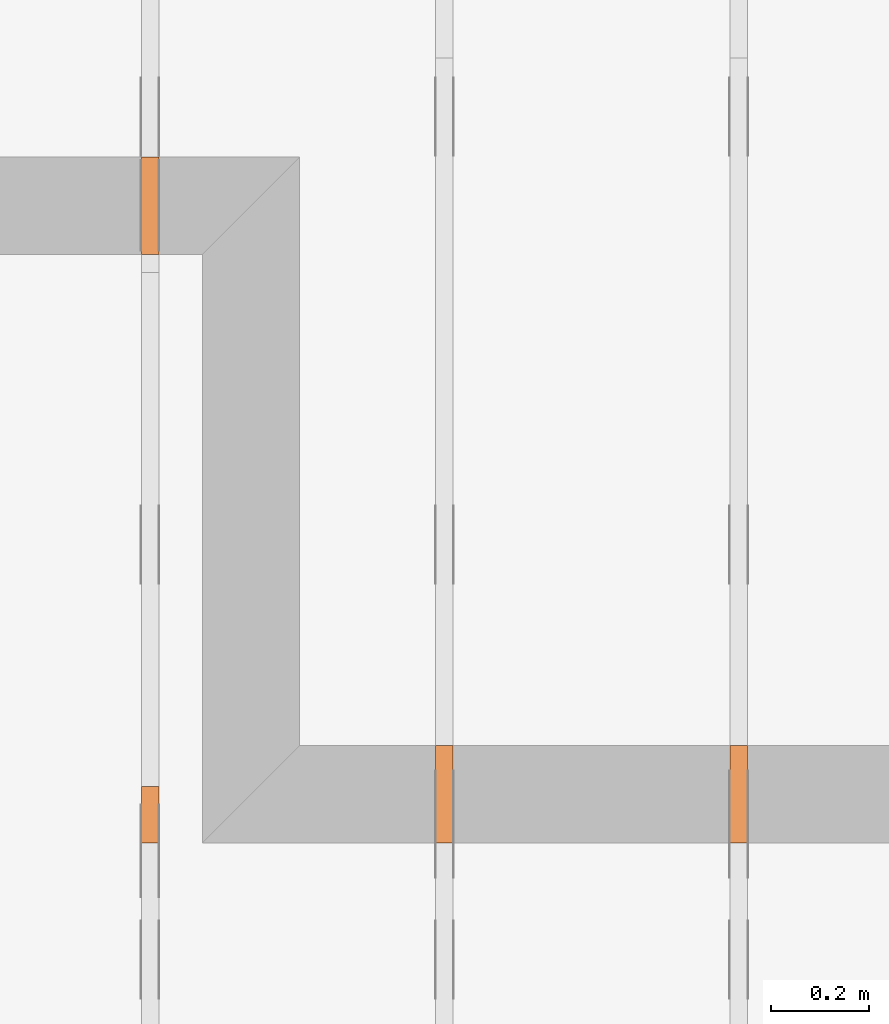
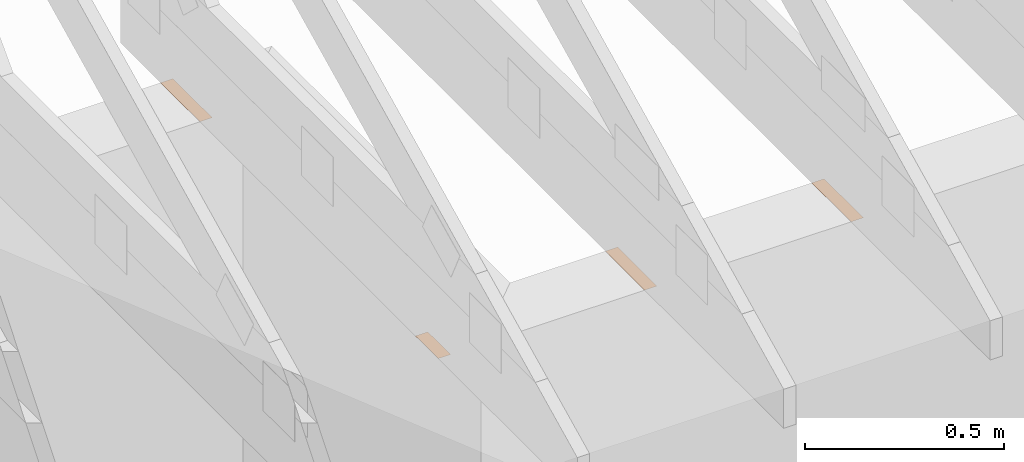
# One storey, part 142 of 159: 4 proxies, 3 elements without a shape of their own.
"""IFC2X3 building model written with IfcOpenShell, lengths in millimetres."""

import ifcopenshell
import ifcopenshell.guid

model = None  # the IFC model being written
_history = None  # IfcOwnerHistory: only IFC2X3 demands one
_inside = {}  # id of a spatial element -> (the spatial element, [elements in it])
_under = {}  # id of a project, library or spatial element -> (it, [spatial elements below it])
_declared = {}  # id of a project -> (the project, [libraries it declares])
_typed = {}  # id of a type object -> (the type object, [elements of that type])
_made_of = {}  # id of a material, layer set ... -> (it, [elements and type objects made of it])


def new_model(schema):
    """Start an empty IFC model of exactly this schema.

    Asked for "IFC4X3", IfcOpenShell would pick the latest addendum, in which some entities
    have other attributes; the version numbers below select the first issue.
    IFC2X3 requires an IfcOwnerHistory on every rooted entity: one is made here for all.
    """
    global model, _history
    if schema == "IFC4X3":
        model = ifcopenshell.file(schema_version=(4, 3, 0, 0))
    else:
        model = ifcopenshell.file(schema=schema)
    _inside.clear()
    _under.clear()
    _declared.clear()
    _typed.clear()
    _made_of.clear()
    _history = None
    if model.schema == "IFC2X3":
        org = make("IfcOrganization", Name="unknown")
        user = make(
            "IfcPersonAndOrganization",
            ThePerson=make("IfcPerson", FamilyName="unknown"),
            TheOrganization=org,
        )
        app = make(
            "IfcApplication",
            ApplicationDeveloper=org,
            Version="unknown",
            ApplicationFullName="unknown",
            ApplicationIdentifier="unknown",
        )
        _history = make(
            "IfcOwnerHistory",
            OwningUser=user,
            OwningApplication=app,
            ChangeAction="ADDED",
            CreationDate=0,
        )
    return model


def make(cls, **values):
    """One entity of the class cls with the attributes given. An attribute that is None is left unset."""
    return model.create_entity(
        cls, **{name: value for name, value in values.items() if value is not None}
    )


def rooted(cls, **values):
    """An entity with a GlobalId (a new one), such as an element, a storey or a relation."""
    return make(cls, GlobalId=ifcopenshell.guid.new(), OwnerHistory=_history, **values)


def si_unit(unit_type, name, prefix=None):
    """IfcSIUnit, for example si_unit("LENGTHUNIT", "METRE", prefix="MILLI")."""
    return make("IfcSIUnit", UnitType=unit_type, Prefix=prefix, Name=name)


def assignment(units):
    """IfcUnitAssignment: the units of a project."""
    return None if units is None else make("IfcUnitAssignment", Units=units)


def point(xyz):
    """IfcCartesianPoint."""
    return None if xyz is None else make("IfcCartesianPoint", Coordinates=xyz)


def direction(xyz):
    """IfcDirection."""
    return None if xyz is None else make("IfcDirection", DirectionRatios=xyz)


def frame(location, z_axis=None, x_axis=None):
    """IfcAxis2Placement3D, a coordinate frame: its origin and axes. An axis left out is left unset."""
    return make(
        "IfcAxis2Placement3D",
        Location=point(location),
        Axis=direction(z_axis),
        RefDirection=direction(x_axis),
    )


def frame_2d(location, x_axis=None):
    """IfcAxis2Placement2D, a coordinate frame in the plane: its origin and x axis."""
    return make(
        "IfcAxis2Placement2D", Location=point(location), RefDirection=direction(x_axis)
    )


def origin():
    """The frame at (0, 0, 0) with its axes left unset."""
    return frame((0.0, 0.0, 0.0))


def origin_with_axes():
    """The frame at (0, 0, 0) with the z axis (0, 0, 1) and the x axis (1, 0, 0) written out."""
    return frame((0.0, 0.0, 0.0), z_axis=(0.0, 0.0, 1.0), x_axis=(1.0, 0.0, 0.0))


def origin_2d():
    """The frame at (0, 0) in the plane with its x axis left unset."""
    return frame_2d((0.0, 0.0))


def place(relative_to, where):
    """IfcLocalPlacement: puts the frame where relative to a parent placement (None: the world)."""
    return make(
        "IfcLocalPlacement", PlacementRelTo=relative_to, RelativePlacement=where
    )


def context(
    kind, dimensions, precision=None, world=None, true_north=None, identifier=None
):
    """IfcGeometricRepresentationContext, for example the 3D "Model" context."""
    return make(
        "IfcGeometricRepresentationContext",
        ContextIdentifier=identifier,
        ContextType=kind,
        CoordinateSpaceDimension=dimensions,
        Precision=precision,
        WorldCoordinateSystem=world,
        TrueNorth=true_north,
    )


def project(units=None, contexts=None):
    """IfcProject with its units and contexts."""
    return rooted(
        "IfcProject",
        Name="project",
        RepresentationContexts=contexts,
        UnitsInContext=assignment(units),
    )


def spatial(cls, under=None, at=None, **own):
    """A site, building, storey or space (cls), placed at a placement, below another one or the project."""
    s = rooted(cls, ObjectPlacement=at, **own)
    if under is not None:
        _under.setdefault(under.id(), (under, []))[1].append(s)
    return s


def faces_of(points, faces, orient=None, outer=None):
    """IfcFace entities. A face is a list of loops; a loop is a list of indices into points, from 0.

    orient and outer hold one flag for each loop. By default every Orientation is true, the
    first loop of a face is its IfcFaceOuterBound and the others are IfcFaceBound.
    """
    made = []
    for i, loops in enumerate(faces):
        bounds = []
        for j, loop in enumerate(loops):
            is_outer = j == 0 if outer is None else outer[i][j]
            bounds.append(
                make(
                    "IfcFaceOuterBound" if is_outer else "IfcFaceBound",
                    Bound=make("IfcPolyLoop", Polygon=[points[k] for k in loop]),
                    Orientation=True if orient is None else orient[i][j],
                )
            )
        made.append(make("IfcFace", Bounds=bounds))
    return made


def open_shell(faces, orient=None, outer=None):
    """The faces of one IfcOpenShell. surface_model builds it on its shared points."""
    return ("IfcOpenShell", faces, orient, outer)


def surface_model(cls, points, shells):
    """IfcFaceBasedSurfaceModel or IfcShellBasedSurfaceModel (cls): surfaces that need not close."""
    shared = [point(p) for p in points]
    made = [make(c, CfsFaces=faces_of(shared, fs, o, b)) for c, fs, o, b in shells]
    if cls == "IfcFaceBasedSurfaceModel":
        return make(cls, FbsmFaces=made)
    return make(cls, SbsmBoundary=made)


def shape(context_of_items, identifier, shape_type, items):
    """IfcShapeRepresentation: the items that make up one representation, for example the "Body"."""
    return make(
        "IfcShapeRepresentation",
        ContextOfItems=context_of_items,
        RepresentationIdentifier=identifier,
        RepresentationType=shape_type,
        Items=items,
    )


def made_of(thing, what):
    """Note that an element or type object is made of a material, layer set ...; save() writes the relation."""
    if what is not None:
        _made_of.setdefault(what.id(), (what, []))[1].append(thing)
    return thing


def element(
    cls,
    number,
    at=None,
    inside=None,
    cuts=None,
    type_object=None,
    material=None,
    context=None,
    identifier="Body",
    shape_type=None,
    held_by="IfcProductDefinitionShape",
    body=None,
    shapes=None,
    **own,
):
    """One element of the class cls, such as IfcWall. Its Tag is "e" and its number.

    at: its placement. inside: the storey or other place that contains it. cuts: it is an
    opening in that element (IfcRelVoidsElement). A single representation is given by context,
    identifier, shape_type and body (its items); several are given by shapes. held_by: the class
    of the entity that holds the representations. save() writes the other relations.
    """
    e = rooted(cls, Tag="e%d" % number, ObjectPlacement=at, **own)
    if body is not None:
        shapes = [shape(context, identifier, shape_type, body)]
    if shapes is not None:
        e.Representation = make(held_by, Representations=shapes)
    if inside is not None:
        _inside.setdefault(inside.id(), (inside, []))[1].append(e)
    if cuts is not None:
        rooted(
            "IfcRelVoidsElement", RelatingBuildingElement=cuts, RelatedOpeningElement=e
        )
    if type_object is not None:
        _typed.setdefault(type_object.id(), (type_object, []))[1].append(e)
    return made_of(e, material)


def aggregate(whole, parts):
    """IfcRelAggregates: a whole, such as a stair, and the parts it consists of."""
    return rooted("IfcRelAggregates", RelatingObject=whole, RelatedObjects=parts)


def save(model, path):
    """Write the relations noted so far, then the file.

    IfcRelAggregates (storeys below a building ...), IfcRelContainedInSpatialStructure (elements
    in a storey), IfcRelDefinesByType, IfcRelAssociatesMaterial and IfcRelDeclares: one each for
    every whole, place, type object, material and project.
    """
    for whole, parts in _under.values():
        aggregate(whole, parts)
    for where, things in _inside.values():
        rooted(
            "IfcRelContainedInSpatialStructure",
            RelatedElements=things,
            RelatingStructure=where,
        )
    for kind, things in _typed.values():
        rooted("IfcRelDefinesByType", RelatedObjects=things, RelatingType=kind)
    for what, things in _made_of.values():
        rooted("IfcRelAssociatesMaterial", RelatedObjects=things, RelatingMaterial=what)
    for by, libraries in _declared.values():
        rooted("IfcRelDeclares", RelatingContext=by, RelatedDefinitions=libraries)
    model.write(path)


model = new_model("IFC2X3")

# Units and contexts
model_context = context("Model", 3, precision=1e-05, world=origin())
plan_context = context("Plan", 2, precision=1e-05, world=origin_2d())
ifc_project = project(units=[si_unit("LENGTHUNIT", "METRE", prefix="MILLI"), si_unit("AREAUNIT", "SQUARE_METRE"), si_unit("VOLUMEUNIT", "CUBIC_METRE"), si_unit("SOLIDANGLEUNIT", "STERADIAN"), si_unit("PLANEANGLEUNIT", "RADIAN"), si_unit("MASSUNIT", "GRAM"), si_unit("TIMEUNIT", "SECOND"), si_unit("THERMODYNAMICTEMPERATUREUNIT", "DEGREE_CELSIUS"), si_unit("LUMINOUSINTENSITYUNIT", "LUMEN")], contexts=[model_context, plan_context])

# Site, building, storey
site_placement = place(None, origin_with_axes())
site = spatial("IfcSite", under=ifc_project, at=site_placement, CompositionType="ELEMENT")
building_placement = place(site_placement, origin_with_axes())
building = spatial("IfcBuilding", under=site, at=building_placement, Name="Plan 1", CompositionType="ELEMENT")
storey_placement = place(building_placement, origin_with_axes())
storey = spatial("IfcBuildingStorey", under=building, at=storey_placement, Name="Etasje 1", CompositionType="ELEMENT", Elevation=0.0)

# Assembly, proxy
assembly_1_placement = place(storey_placement, frame((15075.02226140475, -699.9989301294845, 1.1021457184401395e-15), z_axis=(-1.0, 1.836909530733566e-16, 6.123031769111886e-17), x_axis=(-1.836909530733566e-16, -1.0, 0.0)))
assembly_1 = element("IfcElementAssembly", 1, at=assembly_1_placement, inside=storey, Name="T7 (103)", AssemblyPlace="FACTORY", PredefinedType="TRUSS")
proxy_1_placement = place(assembly_1_placement, frame((-898.0000000000018, -2.4247205805683395e-14, 0.0), z_axis=(-1.2246063538223773e-16, 1.0, 0.0), x_axis=(1.0, 1.2246063538223773e-16, 0.0)))
proxy_1 = element("IfcBuildingElementProxy", 2, at=proxy_1_placement, Name="a1", context=model_context, shape_type="SurfaceModel", body=[
    surface_model("IfcFaceBasedSurfaceModel", [(-6.821210263296962e-13, 0.0, 0.0), (198.0000000000008, 0.0, 0.0), (198.0000000000008, 36.0, 0.0), (-7.958078640513122e-13, 36.0, 0.0)], [open_shell([[[0, 1, 2, 3]]], orient=[[False]])]),
])
aggregate(assembly_1, [proxy_1])

assembly_2_placement = place(storey_placement, frame((14475.022261404752, -699.9989301294836, 1.1021457184401395e-15), z_axis=(-1.0, 1.836909530733566e-16, 6.123031769111886e-17), x_axis=(-1.836909530733566e-16, -1.0, 0.0)))
assembly_2 = element("IfcElementAssembly", 3, at=assembly_2_placement, inside=storey, Name="T10 (102)", AssemblyPlace="FACTORY", PredefinedType="TRUSS")
proxy_2_placement = place(assembly_2_placement, frame((-898.0000000000018, -2.4247205805683395e-14, 0.0), z_axis=(-1.2246063538223773e-16, 1.0, 0.0), x_axis=(1.0, 1.2246063538223773e-16, 0.0)))
proxy_2 = element("IfcBuildingElementProxy", 4, at=proxy_2_placement, Name="a1", context=model_context, shape_type="SurfaceModel", body=[
    surface_model("IfcFaceBasedSurfaceModel", [(-6.821210263296962e-13, 0.0, 0.0), (198.0000000000009, 0.0, 0.0), (198.0000000000009, 36.0, 0.0), (-6.821210263296962e-13, 36.0, 0.0)], [open_shell([[[0, 1, 2, 3]]], orient=[[False]])]),
])
aggregate(assembly_2, [proxy_2])

# Assembly, proxies
assembly_3_placement = place(storey_placement, frame((13875.022261404752, -699.9989301294836, 1.1021457184401395e-15), z_axis=(-1.0, 1.836909530733566e-16, 6.123031769111886e-17), x_axis=(-1.836909530733566e-16, -1.0, 0.0)))
assembly_3 = element("IfcElementAssembly", 5, at=assembly_3_placement, inside=storey, Name="T6 (101)", AssemblyPlace="FACTORY", PredefinedType="TRUSS")
proxy_3_placement = place(assembly_3_placement, frame((-2097.9220619892385, -2.4247205805683193e-14, 0.0), z_axis=(-1.2246063538223773e-16, 1.0, 0.0), x_axis=(1.0, 1.2246063538223773e-16, 0.0)))
proxy_3 = element("IfcBuildingElementProxy", 6, at=proxy_3_placement, Name="10", context=model_context, shape_type="SurfaceModel", body=[
    surface_model("IfcFaceBasedSurfaceModel", [(-9.094947017729282e-13, 0.0, -5.048709793414476e-29), (198.0000000000009, 0.0, 0.0), (198.0000000000009, 36.0, 0.0), (-9.094947017729282e-13, 36.0, -5.048709793414476e-29)], [open_shell([[[0, 1, 2, 3]]], orient=[[False]])]),
])
proxy_4_placement = place(assembly_3_placement, frame((-814.9989301294843, 3.5207432672393342e-15, 0.0), z_axis=(0.0, 1.0, 0.0), x_axis=(1.0, 0.0, 0.0)))
proxy_4 = element("IfcBuildingElementProxy", 7, at=proxy_4_placement, Name="a1", context=model_context, shape_type="SurfaceModel", body=[
    surface_model("IfcFaceBasedSurfaceModel", [(-9.094947017729282e-13, 0.0, 3.944304526105059e-31), (114.99999999999909, 0.0, 3.944304526105059e-31), (114.99999999999909, 36.0, 0.0), (-9.094947017729282e-13, 36.0, 0.0)], [open_shell([[[0, 1, 2, 3]]], orient=[[False]])]),
])
aggregate(assembly_3, [proxy_3, proxy_4])

save(model, "model.ifc")
